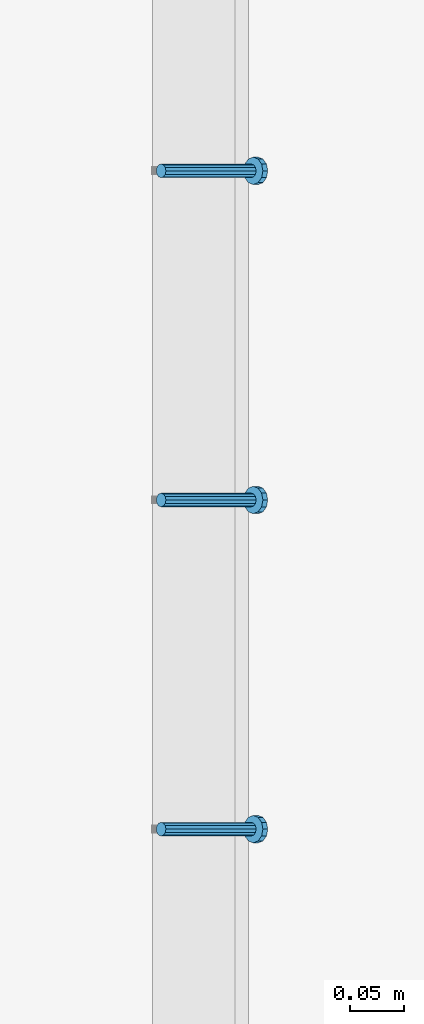
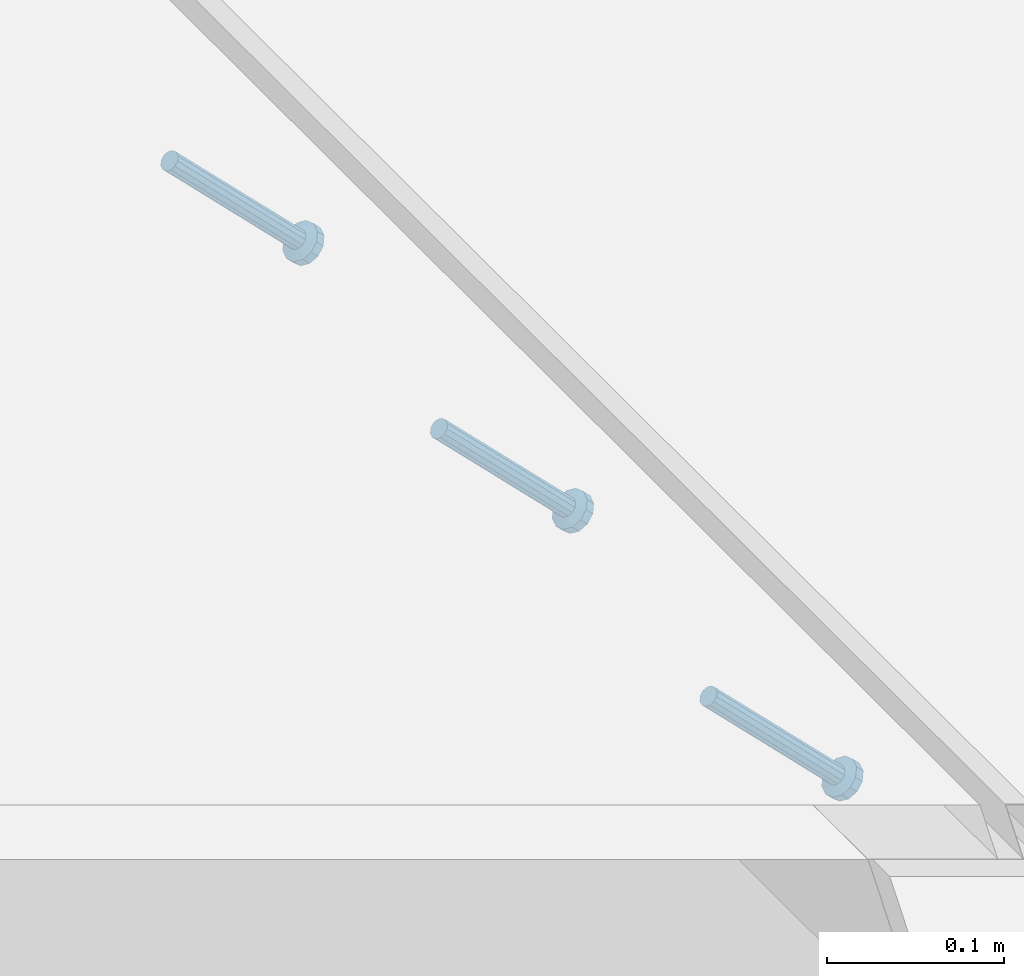
# One storey, part 2444 of 3843: 3 members, 1 element without a shape of its own.
"""IFC2X3 building model written with IfcOpenShell, lengths in millimetres."""

import ifcopenshell
import ifcopenshell.guid

model = None  # the IFC model being written
_history = None  # IfcOwnerHistory: only IFC2X3 demands one
_inside = {}  # id of a spatial element -> (the spatial element, [elements in it])
_under = {}  # id of a project, library or spatial element -> (it, [spatial elements below it])
_declared = {}  # id of a project -> (the project, [libraries it declares])
_typed = {}  # id of a type object -> (the type object, [elements of that type])
_made_of = {}  # id of a material, layer set ... -> (it, [elements and type objects made of it])


def new_model(schema):
    """Start an empty IFC model of exactly this schema.

    Asked for "IFC4X3", IfcOpenShell would pick the latest addendum, in which some entities
    have other attributes; the version numbers below select the first issue.
    IFC2X3 requires an IfcOwnerHistory on every rooted entity: one is made here for all.
    """
    global model, _history
    if schema == "IFC4X3":
        model = ifcopenshell.file(schema_version=(4, 3, 0, 0))
    else:
        model = ifcopenshell.file(schema=schema)
    _inside.clear()
    _under.clear()
    _declared.clear()
    _typed.clear()
    _made_of.clear()
    _history = None
    if model.schema == "IFC2X3":
        org = make("IfcOrganization", Name="unknown")
        user = make(
            "IfcPersonAndOrganization",
            ThePerson=make("IfcPerson", FamilyName="unknown"),
            TheOrganization=org,
        )
        app = make(
            "IfcApplication",
            ApplicationDeveloper=org,
            Version="unknown",
            ApplicationFullName="unknown",
            ApplicationIdentifier="unknown",
        )
        _history = make(
            "IfcOwnerHistory",
            OwningUser=user,
            OwningApplication=app,
            ChangeAction="ADDED",
            CreationDate=0,
        )
    return model


def make(cls, **values):
    """One entity of the class cls with the attributes given. An attribute that is None is left unset."""
    return model.create_entity(
        cls, **{name: value for name, value in values.items() if value is not None}
    )


def rooted(cls, **values):
    """An entity with a GlobalId (a new one), such as an element, a storey or a relation."""
    return make(cls, GlobalId=ifcopenshell.guid.new(), OwnerHistory=_history, **values)


def si_unit(unit_type, name, prefix=None):
    """IfcSIUnit, for example si_unit("LENGTHUNIT", "METRE", prefix="MILLI")."""
    return make("IfcSIUnit", UnitType=unit_type, Prefix=prefix, Name=name)


def assignment(units):
    """IfcUnitAssignment: the units of a project."""
    return None if units is None else make("IfcUnitAssignment", Units=units)


def point(xyz):
    """IfcCartesianPoint."""
    return None if xyz is None else make("IfcCartesianPoint", Coordinates=xyz)


def direction(xyz):
    """IfcDirection."""
    return None if xyz is None else make("IfcDirection", DirectionRatios=xyz)


def frame(location, z_axis=None, x_axis=None):
    """IfcAxis2Placement3D, a coordinate frame: its origin and axes. An axis left out is left unset."""
    return make(
        "IfcAxis2Placement3D",
        Location=point(location),
        Axis=direction(z_axis),
        RefDirection=direction(x_axis),
    )


def origin_with_axes():
    """The frame at (0, 0, 0) with the z axis (0, 0, 1) and the x axis (1, 0, 0) written out."""
    return frame((0.0, 0.0, 0.0), z_axis=(0.0, 0.0, 1.0), x_axis=(1.0, 0.0, 0.0))


def place(relative_to, where):
    """IfcLocalPlacement: puts the frame where relative to a parent placement (None: the world)."""
    return make(
        "IfcLocalPlacement", PlacementRelTo=relative_to, RelativePlacement=where
    )


def context(
    kind, dimensions, precision=None, world=None, true_north=None, identifier=None
):
    """IfcGeometricRepresentationContext, for example the 3D "Model" context."""
    return make(
        "IfcGeometricRepresentationContext",
        ContextIdentifier=identifier,
        ContextType=kind,
        CoordinateSpaceDimension=dimensions,
        Precision=precision,
        WorldCoordinateSystem=world,
        TrueNorth=true_north,
    )


def subcontext(parent, identifier, kind, view, scale=None):
    """IfcGeometricRepresentationSubContext, for example "Body" below "Model"."""
    return make(
        "IfcGeometricRepresentationSubContext",
        ContextIdentifier=identifier,
        ContextType=kind,
        ParentContext=parent,
        TargetScale=scale,
        TargetView=view,
    )


def project(units=None, contexts=None):
    """IfcProject with its units and contexts."""
    return rooted(
        "IfcProject",
        Name="project",
        RepresentationContexts=contexts,
        UnitsInContext=assignment(units),
    )


def spatial(cls, under=None, at=None, **own):
    """A site, building, storey or space (cls), placed at a placement, below another one or the project."""
    s = rooted(cls, ObjectPlacement=at, **own)
    if under is not None:
        _under.setdefault(under.id(), (under, []))[1].append(s)
    return s


def faces_of(points, faces, orient=None, outer=None):
    """IfcFace entities. A face is a list of loops; a loop is a list of indices into points, from 0.

    orient and outer hold one flag for each loop. By default every Orientation is true, the
    first loop of a face is its IfcFaceOuterBound and the others are IfcFaceBound.
    """
    made = []
    for i, loops in enumerate(faces):
        bounds = []
        for j, loop in enumerate(loops):
            is_outer = j == 0 if outer is None else outer[i][j]
            bounds.append(
                make(
                    "IfcFaceOuterBound" if is_outer else "IfcFaceBound",
                    Bound=make("IfcPolyLoop", Polygon=[points[k] for k in loop]),
                    Orientation=True if orient is None else orient[i][j],
                )
            )
        made.append(make("IfcFace", Bounds=bounds))
    return made


def faceted_brep(points, faces, orient=None, outer=None, voids=None):
    """IfcFacetedBrep: a solid bounded by flat faces; with voids (closed shells), ...WithVoids."""
    shared = [point(p) for p in points]
    hull = make("IfcClosedShell", CfsFaces=faces_of(shared, faces, orient, outer))
    if voids is None:
        return make("IfcFacetedBrep", Outer=hull)
    return make(
        "IfcFacetedBrepWithVoids",
        Outer=hull,
        Voids=[
            make(cls, CfsFaces=faces_of(shared, fs, o, b)) for cls, fs, o, b in voids
        ],
    )


def shape(context_of_items, identifier, shape_type, items):
    """IfcShapeRepresentation: the items that make up one representation, for example the "Body"."""
    return make(
        "IfcShapeRepresentation",
        ContextOfItems=context_of_items,
        RepresentationIdentifier=identifier,
        RepresentationType=shape_type,
        Items=items,
    )


def material(Name=None, Category=None):
    """IfcMaterial."""
    return make("IfcMaterial", Name=Name, Category=Category)


def made_of(thing, what):
    """Note that an element or type object is made of a material, layer set ...; save() writes the relation."""
    if what is not None:
        _made_of.setdefault(what.id(), (what, []))[1].append(thing)
    return thing


def type_object(cls, material=None, **own):
    """A type object (cls), such as IfcWallType, which elements share."""
    return made_of(rooted(cls, **own), material)


def element(
    cls,
    number,
    at=None,
    inside=None,
    cuts=None,
    type_object=None,
    material=None,
    context=None,
    identifier="Body",
    shape_type=None,
    held_by="IfcProductDefinitionShape",
    body=None,
    shapes=None,
    **own,
):
    """One element of the class cls, such as IfcWall. Its Tag is "e" and its number.

    at: its placement. inside: the storey or other place that contains it. cuts: it is an
    opening in that element (IfcRelVoidsElement). A single representation is given by context,
    identifier, shape_type and body (its items); several are given by shapes. held_by: the class
    of the entity that holds the representations. save() writes the other relations.
    """
    e = rooted(cls, Tag="e%d" % number, ObjectPlacement=at, **own)
    if body is not None:
        shapes = [shape(context, identifier, shape_type, body)]
    if shapes is not None:
        e.Representation = make(held_by, Representations=shapes)
    if inside is not None:
        _inside.setdefault(inside.id(), (inside, []))[1].append(e)
    if cuts is not None:
        rooted(
            "IfcRelVoidsElement", RelatingBuildingElement=cuts, RelatedOpeningElement=e
        )
    if type_object is not None:
        _typed.setdefault(type_object.id(), (type_object, []))[1].append(e)
    return made_of(e, material)


def aggregate(whole, parts):
    """IfcRelAggregates: a whole, such as a stair, and the parts it consists of."""
    return rooted("IfcRelAggregates", RelatingObject=whole, RelatedObjects=parts)


def save(model, path):
    """Write the relations noted so far, then the file.

    IfcRelAggregates (storeys below a building ...), IfcRelContainedInSpatialStructure (elements
    in a storey), IfcRelDefinesByType, IfcRelAssociatesMaterial and IfcRelDeclares: one each for
    every whole, place, type object, material and project.
    """
    for whole, parts in _under.values():
        aggregate(whole, parts)
    for where, things in _inside.values():
        rooted(
            "IfcRelContainedInSpatialStructure",
            RelatedElements=things,
            RelatingStructure=where,
        )
    for kind, things in _typed.values():
        rooted("IfcRelDefinesByType", RelatedObjects=things, RelatingType=kind)
    for what, things in _made_of.values():
        rooted("IfcRelAssociatesMaterial", RelatedObjects=things, RelatingMaterial=what)
    for by, libraries in _declared.values():
        rooted("IfcRelDeclares", RelatingContext=by, RelatedDefinitions=libraries)
    model.write(path)


model = new_model("IFC2X3")

# Units and contexts
model_context = context("Model", 3, precision=1e-05, world=origin_with_axes())
body_context = subcontext(model_context, "Body", "Model", "MODEL_VIEW")
ifc_project = project(units=[si_unit("LENGTHUNIT", "METRE", prefix="MILLI"), si_unit("AREAUNIT", "SQUARE_METRE"), si_unit("VOLUMEUNIT", "CUBIC_METRE"), si_unit("MASSUNIT", "GRAM", prefix="KILO"), si_unit("TIMEUNIT", "SECOND"), si_unit("PLANEANGLEUNIT", "RADIAN"), si_unit("SOLIDANGLEUNIT", "STERADIAN"), si_unit("THERMODYNAMICTEMPERATUREUNIT", "DEGREE_CELSIUS"), si_unit("LUMINOUSINTENSITYUNIT", "LUMEN")], contexts=[model_context])

# Site, building, storey
site_placement = place(None, origin_with_axes())
site = spatial("IfcSite", under=ifc_project, at=site_placement, CompositionType="ELEMENT")
building_placement = place(site_placement, origin_with_axes())
building = spatial("IfcBuilding", under=site, at=building_placement, Name="Undefined", CompositionType="ELEMENT")
storey_placement = place(building_placement, origin_with_axes())
storey = spatial("IfcBuildingStorey", under=building, at=storey_placement, Name="Undefined", CompositionType="ELEMENT", Elevation=0.0)

# Assembly, members
assembly_placement = place(storey_placement, origin_with_axes())
assembly = element("IfcElementAssembly", 1, at=assembly_placement, inside=storey, Name="EMBED_ANGLE", AssemblyPlace="NOTDEFINED", PredefinedType="RIGID_FRAME")
ifc_material = material(Name="STEEL/A108")
member_type = type_object("IfcMemberType", PredefinedType="NOTDEFINED")
member_1_placement = place(assembly_placement, frame((52815.2995, 74021.8227092285, 30446.6625), z_axis=(0.0, 1.0, 0.0), x_axis=(0.707106781186548, 0.0, -0.707106781186548)))
member_1 = element("IfcMember", 2, at=member_1_placement, type_object=member_type, material=ifc_material, Name="HEADED STUD ANCHOR", context=body_context, shape_type="Brep", body=[
    faceted_brep([(7.27595761418343e-12, -3.18000006675175, 5.5), (0.0, -5.49999999998363, 3.1800000667572), (118.110000000976, -5.49999999999091, 3.1800000667572), (118.110000000983, -3.18000006675175, 5.5), (0.0, -6.3499999046162, 0.0), (118.110000000968, -6.34999990461256, 0.0), (0.0, -5.49999999998363, -3.1800000667572), (118.110000000976, -5.49999999999091, -3.1800000667572), (7.27595761418343e-12, -3.18000006675175, -5.5), (118.110000000983, -3.18000006675175, -5.5), (7.27595761418343e-12, -1.81898940354586e-12, -6.34999990463257), (118.110000000968, -1.81898940354586e-12, -6.34999990463257), (0.0, 3.18000006675175, -5.5), (118.110000000968, 3.18000006674811, -5.5), (7.27595761418343e-12, 5.49999999998363, -3.1800000667572), (118.110000000983, 5.49999999998363, -3.1800000667572), (7.27595761418343e-12, 6.3499999046162, 0.0), (118.110000000976, 6.34999990461256, 0.0), (7.27595761418343e-12, 5.49999999998363, 3.1800000667572), (118.110000000983, 5.49999999998363, 3.1800000667572), (0.0, 3.18000006675175, 5.5), (118.110000000968, 3.18000006674811, 5.5), (7.27595761418343e-12, -1.81898940354586e-12, 6.34999990463257), (118.110000000968, -1.81898940354586e-12, 6.34999990463257), (120.650000000991, -10.9899997710909, 6.34999990463257), (120.650000000998, -6.34000015257152, 10.9899997711182), (120.650000000991, -12.6999998092379, 0.0), (120.650000000991, -10.9899997710909, -6.34999990463257), (120.650000000998, -6.34000015257152, -10.9899997711182), (120.650000000991, -1.81898940354586e-12, -12.6899995803833), (120.650000000991, 6.34000015257152, -10.9899997711182), (120.650000000998, 10.9899997710909, -6.34999990463257), (120.650000000991, 12.6999998092342, 0.0), (120.650000000998, 10.9899997710909, 6.34999990463257), (120.650000000991, 6.34000015257152, 10.9899997711182), (120.650000000991, -1.81898940354586e-12, 12.6899995803833), (127.000000001048, -10.9899997710945, 6.34999990463257), (127.000000001048, -6.34000015257152, 10.9899997711182), (127.000000001048, -12.6999998092342, 0.0), (127.000000001048, -10.9899997710945, -6.34999990463257), (127.000000001048, -6.34000015257152, -10.9899997711182), (127.000000001048, 1.81898940354586e-12, -12.6899995803833), (127.000000001048, 6.34000015256788, -10.9899997711182), (127.000000001048, 10.9899997710909, -6.34999990463257), (127.000000001048, 12.6999998092379, 0.0), (127.000000001048, 10.9899997710909, 6.34999990463257), (127.000000001048, 6.34000015256788, 10.9899997711182), (127.000000001048, 1.81898940354586e-12, 12.6899995803833)], [[[0, 1, 2, 3]], [[1, 4, 5, 2]], [[4, 6, 7, 5]], [[6, 8, 9, 7]], [[8, 10, 11, 9]], [[10, 12, 13, 11]], [[12, 14, 15, 13]], [[14, 16, 17, 15]], [[16, 18, 19, 17]], [[18, 20, 21, 19]], [[20, 22, 23, 21]], [[22, 0, 3, 23]], [[22, 20, 18, 16, 14, 12, 10, 8, 6, 4, 1, 0]], [[3, 2, 24, 25]], [[2, 5, 26, 24]], [[5, 7, 27, 26]], [[7, 9, 28, 27]], [[9, 11, 29, 28]], [[11, 13, 30, 29]], [[13, 15, 31, 30]], [[15, 17, 32, 31]], [[17, 19, 33, 32]], [[19, 21, 34, 33]], [[21, 23, 35, 34]], [[23, 3, 25, 35]], [[25, 24, 36, 37]], [[24, 26, 38, 36]], [[26, 27, 39, 38]], [[27, 28, 40, 39]], [[28, 29, 41, 40]], [[29, 30, 42, 41]], [[30, 31, 43, 42]], [[31, 32, 44, 43]], [[32, 33, 45, 44]], [[33, 34, 46, 45]], [[34, 35, 47, 46]], [[35, 25, 37, 47]], [[38, 39, 40, 41, 42, 43, 44, 45, 46, 47, 37, 36]]]),
])
member_2_placement = place(assembly_placement, frame((52815.2995, 74326.6227092285, 30446.6625), z_axis=(0.0, 1.0, 0.0), x_axis=(0.707106781186548, 0.0, -0.707106781186548)))
member_2 = element("IfcMember", 3, at=member_2_placement, type_object=member_type, material=ifc_material, Name="HEADED STUD ANCHOR", context=body_context, shape_type="Brep", body=[
    faceted_brep([(7.27595761418343e-12, -3.18000006675175, 5.5), (0.0, -5.49999999998363, 3.1800000667572), (118.110000000976, -5.49999999999091, 3.1800000667572), (118.110000000983, -3.18000006675175, 5.5), (0.0, -6.3499999046162, 0.0), (118.110000000968, -6.34999990461256, 0.0), (0.0, -5.49999999998363, -3.1800000667572), (118.110000000976, -5.49999999999091, -3.1800000667572), (7.27595761418343e-12, -3.18000006675175, -5.5), (118.110000000983, -3.18000006675175, -5.5), (7.27595761418343e-12, -1.81898940354586e-12, -6.34999990463257), (118.110000000968, -1.81898940354586e-12, -6.34999990463257), (0.0, 3.18000006675175, -5.5), (118.110000000968, 3.18000006674811, -5.5), (7.27595761418343e-12, 5.49999999998363, -3.1800000667572), (118.110000000983, 5.49999999998363, -3.1800000667572), (7.27595761418343e-12, 6.3499999046162, 0.0), (118.110000000976, 6.34999990461256, 0.0), (7.27595761418343e-12, 5.49999999998363, 3.1800000667572), (118.110000000983, 5.49999999998363, 3.1800000667572), (0.0, 3.18000006675175, 5.5), (118.110000000968, 3.18000006674811, 5.5), (7.27595761418343e-12, -1.81898940354586e-12, 6.34999990463257), (118.110000000968, -1.81898940354586e-12, 6.34999990463257), (120.650000000991, -10.9899997710909, 6.34999990463257), (120.650000000998, -6.34000015257152, 10.9899997711182), (120.650000000991, -12.6999998092379, 0.0), (120.650000000991, -10.9899997710909, -6.34999990463257), (120.650000000998, -6.34000015257152, -10.9899997711182), (120.650000000991, -1.81898940354586e-12, -12.6899995803833), (120.650000000991, 6.34000015257152, -10.9899997711182), (120.650000000998, 10.9899997710909, -6.34999990463257), (120.650000000991, 12.6999998092342, 0.0), (120.650000000998, 10.9899997710909, 6.34999990463257), (120.650000000991, 6.34000015257152, 10.9899997711182), (120.650000000991, -1.81898940354586e-12, 12.6899995803833), (127.000000001048, -10.9899997710945, 6.34999990463257), (127.000000001048, -6.34000015257152, 10.9899997711182), (127.000000001048, -12.6999998092342, 0.0), (127.000000001048, -10.9899997710945, -6.34999990463257), (127.000000001048, -6.34000015257152, -10.9899997711182), (127.000000001048, 1.81898940354586e-12, -12.6899995803833), (127.000000001048, 6.34000015256788, -10.9899997711182), (127.000000001048, 10.9899997710909, -6.34999990463257), (127.000000001048, 12.6999998092379, 0.0), (127.000000001048, 10.9899997710909, 6.34999990463257), (127.000000001048, 6.34000015256788, 10.9899997711182), (127.000000001048, 1.81898940354586e-12, 12.6899995803833)], [[[0, 1, 2, 3]], [[1, 4, 5, 2]], [[4, 6, 7, 5]], [[6, 8, 9, 7]], [[8, 10, 11, 9]], [[10, 12, 13, 11]], [[12, 14, 15, 13]], [[14, 16, 17, 15]], [[16, 18, 19, 17]], [[18, 20, 21, 19]], [[20, 22, 23, 21]], [[22, 0, 3, 23]], [[22, 20, 18, 16, 14, 12, 10, 8, 6, 4, 1, 0]], [[3, 2, 24, 25]], [[2, 5, 26, 24]], [[5, 7, 27, 26]], [[7, 9, 28, 27]], [[9, 11, 29, 28]], [[11, 13, 30, 29]], [[13, 15, 31, 30]], [[15, 17, 32, 31]], [[17, 19, 33, 32]], [[19, 21, 34, 33]], [[21, 23, 35, 34]], [[23, 3, 25, 35]], [[25, 24, 36, 37]], [[24, 26, 38, 36]], [[26, 27, 39, 38]], [[27, 28, 40, 39]], [[28, 29, 41, 40]], [[29, 30, 42, 41]], [[30, 31, 43, 42]], [[31, 32, 44, 43]], [[32, 33, 45, 44]], [[33, 34, 46, 45]], [[34, 35, 47, 46]], [[35, 25, 37, 47]], [[38, 39, 40, 41, 42, 43, 44, 45, 46, 47, 37, 36]]]),
])
member_3_placement = place(assembly_placement, frame((52815.2995, 74631.4227092285, 30446.6625), z_axis=(0.0, 1.0, 0.0), x_axis=(0.707106781186548, 0.0, -0.707106781186548)))
member_3 = element("IfcMember", 4, at=member_3_placement, type_object=member_type, material=ifc_material, Name="HEADED STUD ANCHOR", context=body_context, shape_type="Brep", body=[
    faceted_brep([(7.27595761418343e-12, -3.18000006675175, 5.5), (0.0, -5.49999999998363, 3.1800000667572), (118.110000000976, -5.49999999999091, 3.1800000667572), (118.110000000983, -3.18000006675175, 5.5), (0.0, -6.3499999046162, 0.0), (118.110000000968, -6.34999990461256, 0.0), (0.0, -5.49999999998363, -3.1800000667572), (118.110000000976, -5.49999999999091, -3.1800000667572), (7.27595761418343e-12, -3.18000006675175, -5.5), (118.110000000983, -3.18000006675175, -5.5), (7.27595761418343e-12, -1.81898940354586e-12, -6.34999990463257), (118.110000000968, -1.81898940354586e-12, -6.34999990463257), (0.0, 3.18000006675175, -5.5), (118.110000000968, 3.18000006674811, -5.5), (7.27595761418343e-12, 5.49999999998363, -3.1800000667572), (118.110000000983, 5.49999999998363, -3.1800000667572), (7.27595761418343e-12, 6.3499999046162, 0.0), (118.110000000976, 6.34999990461256, 0.0), (7.27595761418343e-12, 5.49999999998363, 3.1800000667572), (118.110000000983, 5.49999999998363, 3.1800000667572), (0.0, 3.18000006675175, 5.5), (118.110000000968, 3.18000006674811, 5.5), (7.27595761418343e-12, -1.81898940354586e-12, 6.34999990463257), (118.110000000968, -1.81898940354586e-12, 6.34999990463257), (120.650000000991, -10.9899997710909, 6.34999990463257), (120.650000000998, -6.34000015257152, 10.9899997711182), (120.650000000991, -12.6999998092379, 0.0), (120.650000000991, -10.9899997710909, -6.34999990463257), (120.650000000998, -6.34000015257152, -10.9899997711182), (120.650000000991, -1.81898940354586e-12, -12.6899995803833), (120.650000000991, 6.34000015257152, -10.9899997711182), (120.650000000998, 10.9899997710909, -6.34999990463257), (120.650000000991, 12.6999998092342, 0.0), (120.650000000998, 10.9899997710909, 6.34999990463257), (120.650000000991, 6.34000015257152, 10.9899997711182), (120.650000000991, -1.81898940354586e-12, 12.6899995803833), (127.000000001048, -10.9899997710945, 6.34999990463257), (127.000000001048, -6.34000015257152, 10.9899997711182), (127.000000001048, -12.6999998092342, 0.0), (127.000000001048, -10.9899997710945, -6.34999990463257), (127.000000001048, -6.34000015257152, -10.9899997711182), (127.000000001048, 1.81898940354586e-12, -12.6899995803833), (127.000000001048, 6.34000015256788, -10.9899997711182), (127.000000001048, 10.9899997710909, -6.34999990463257), (127.000000001048, 12.6999998092379, 0.0), (127.000000001048, 10.9899997710909, 6.34999990463257), (127.000000001048, 6.34000015256788, 10.9899997711182), (127.000000001048, 1.81898940354586e-12, 12.6899995803833)], [[[0, 1, 2, 3]], [[1, 4, 5, 2]], [[4, 6, 7, 5]], [[6, 8, 9, 7]], [[8, 10, 11, 9]], [[10, 12, 13, 11]], [[12, 14, 15, 13]], [[14, 16, 17, 15]], [[16, 18, 19, 17]], [[18, 20, 21, 19]], [[20, 22, 23, 21]], [[22, 0, 3, 23]], [[22, 20, 18, 16, 14, 12, 10, 8, 6, 4, 1, 0]], [[3, 2, 24, 25]], [[2, 5, 26, 24]], [[5, 7, 27, 26]], [[7, 9, 28, 27]], [[9, 11, 29, 28]], [[11, 13, 30, 29]], [[13, 15, 31, 30]], [[15, 17, 32, 31]], [[17, 19, 33, 32]], [[19, 21, 34, 33]], [[21, 23, 35, 34]], [[23, 3, 25, 35]], [[25, 24, 36, 37]], [[24, 26, 38, 36]], [[26, 27, 39, 38]], [[27, 28, 40, 39]], [[28, 29, 41, 40]], [[29, 30, 42, 41]], [[30, 31, 43, 42]], [[31, 32, 44, 43]], [[32, 33, 45, 44]], [[33, 34, 46, 45]], [[34, 35, 47, 46]], [[35, 25, 37, 47]], [[38, 39, 40, 41, 42, 43, 44, 45, 46, 47, 37, 36]]]),
])
aggregate(assembly, [member_1, member_2, member_3])

save(model, "model.ifc")
